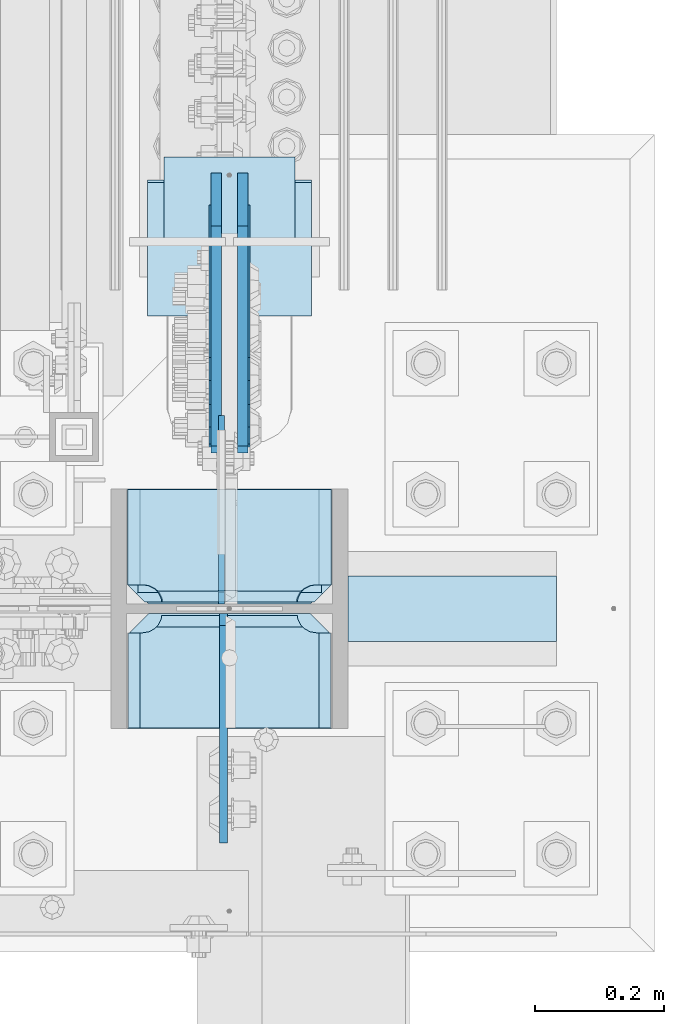
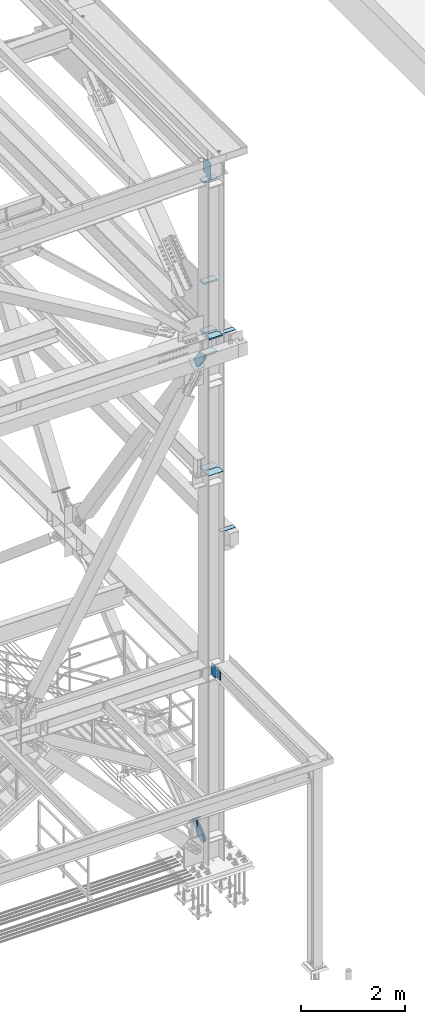
# One storey, part 3567 of 3843: 17 plates, 9 elements without a shape of their own.
"""IFC2X3 building model written with IfcOpenShell, lengths in millimetres."""

import ifcopenshell
import ifcopenshell.guid

model = None  # the IFC model being written
_history = None  # IfcOwnerHistory: only IFC2X3 demands one
_inside = {}  # id of a spatial element -> (the spatial element, [elements in it])
_under = {}  # id of a project, library or spatial element -> (it, [spatial elements below it])
_declared = {}  # id of a project -> (the project, [libraries it declares])
_typed = {}  # id of a type object -> (the type object, [elements of that type])
_made_of = {}  # id of a material, layer set ... -> (it, [elements and type objects made of it])


def new_model(schema):
    """Start an empty IFC model of exactly this schema.

    Asked for "IFC4X3", IfcOpenShell would pick the latest addendum, in which some entities
    have other attributes; the version numbers below select the first issue.
    IFC2X3 requires an IfcOwnerHistory on every rooted entity: one is made here for all.
    """
    global model, _history
    if schema == "IFC4X3":
        model = ifcopenshell.file(schema_version=(4, 3, 0, 0))
    else:
        model = ifcopenshell.file(schema=schema)
    _inside.clear()
    _under.clear()
    _declared.clear()
    _typed.clear()
    _made_of.clear()
    _history = None
    if model.schema == "IFC2X3":
        org = make("IfcOrganization", Name="unknown")
        user = make(
            "IfcPersonAndOrganization",
            ThePerson=make("IfcPerson", FamilyName="unknown"),
            TheOrganization=org,
        )
        app = make(
            "IfcApplication",
            ApplicationDeveloper=org,
            Version="unknown",
            ApplicationFullName="unknown",
            ApplicationIdentifier="unknown",
        )
        _history = make(
            "IfcOwnerHistory",
            OwningUser=user,
            OwningApplication=app,
            ChangeAction="ADDED",
            CreationDate=0,
        )
    return model


def make(cls, **values):
    """One entity of the class cls with the attributes given. An attribute that is None is left unset."""
    return model.create_entity(
        cls, **{name: value for name, value in values.items() if value is not None}
    )


def rooted(cls, **values):
    """An entity with a GlobalId (a new one), such as an element, a storey or a relation."""
    return make(cls, GlobalId=ifcopenshell.guid.new(), OwnerHistory=_history, **values)


def si_unit(unit_type, name, prefix=None):
    """IfcSIUnit, for example si_unit("LENGTHUNIT", "METRE", prefix="MILLI")."""
    return make("IfcSIUnit", UnitType=unit_type, Prefix=prefix, Name=name)


def assignment(units):
    """IfcUnitAssignment: the units of a project."""
    return None if units is None else make("IfcUnitAssignment", Units=units)


def point(xyz):
    """IfcCartesianPoint."""
    return None if xyz is None else make("IfcCartesianPoint", Coordinates=xyz)


def direction(xyz):
    """IfcDirection."""
    return None if xyz is None else make("IfcDirection", DirectionRatios=xyz)


def frame(location, z_axis=None, x_axis=None):
    """IfcAxis2Placement3D, a coordinate frame: its origin and axes. An axis left out is left unset."""
    return make(
        "IfcAxis2Placement3D",
        Location=point(location),
        Axis=direction(z_axis),
        RefDirection=direction(x_axis),
    )


def origin_with_axes():
    """The frame at (0, 0, 0) with the z axis (0, 0, 1) and the x axis (1, 0, 0) written out."""
    return frame((0.0, 0.0, 0.0), z_axis=(0.0, 0.0, 1.0), x_axis=(1.0, 0.0, 0.0))


def place(relative_to, where):
    """IfcLocalPlacement: puts the frame where relative to a parent placement (None: the world)."""
    return make(
        "IfcLocalPlacement", PlacementRelTo=relative_to, RelativePlacement=where
    )


def context(
    kind, dimensions, precision=None, world=None, true_north=None, identifier=None
):
    """IfcGeometricRepresentationContext, for example the 3D "Model" context."""
    return make(
        "IfcGeometricRepresentationContext",
        ContextIdentifier=identifier,
        ContextType=kind,
        CoordinateSpaceDimension=dimensions,
        Precision=precision,
        WorldCoordinateSystem=world,
        TrueNorth=true_north,
    )


def subcontext(parent, identifier, kind, view, scale=None):
    """IfcGeometricRepresentationSubContext, for example "Body" below "Model"."""
    return make(
        "IfcGeometricRepresentationSubContext",
        ContextIdentifier=identifier,
        ContextType=kind,
        ParentContext=parent,
        TargetScale=scale,
        TargetView=view,
    )


def project(units=None, contexts=None):
    """IfcProject with its units and contexts."""
    return rooted(
        "IfcProject",
        Name="project",
        RepresentationContexts=contexts,
        UnitsInContext=assignment(units),
    )


def spatial(cls, under=None, at=None, **own):
    """A site, building, storey or space (cls), placed at a placement, below another one or the project."""
    s = rooted(cls, ObjectPlacement=at, **own)
    if under is not None:
        _under.setdefault(under.id(), (under, []))[1].append(s)
    return s


def faces_of(points, faces, orient=None, outer=None):
    """IfcFace entities. A face is a list of loops; a loop is a list of indices into points, from 0.

    orient and outer hold one flag for each loop. By default every Orientation is true, the
    first loop of a face is its IfcFaceOuterBound and the others are IfcFaceBound.
    """
    made = []
    for i, loops in enumerate(faces):
        bounds = []
        for j, loop in enumerate(loops):
            is_outer = j == 0 if outer is None else outer[i][j]
            bounds.append(
                make(
                    "IfcFaceOuterBound" if is_outer else "IfcFaceBound",
                    Bound=make("IfcPolyLoop", Polygon=[points[k] for k in loop]),
                    Orientation=True if orient is None else orient[i][j],
                )
            )
        made.append(make("IfcFace", Bounds=bounds))
    return made


def faceted_brep(points, faces, orient=None, outer=None, voids=None):
    """IfcFacetedBrep: a solid bounded by flat faces; with voids (closed shells), ...WithVoids."""
    shared = [point(p) for p in points]
    hull = make("IfcClosedShell", CfsFaces=faces_of(shared, faces, orient, outer))
    if voids is None:
        return make("IfcFacetedBrep", Outer=hull)
    return make(
        "IfcFacetedBrepWithVoids",
        Outer=hull,
        Voids=[
            make(cls, CfsFaces=faces_of(shared, fs, o, b)) for cls, fs, o, b in voids
        ],
    )


def shape(context_of_items, identifier, shape_type, items):
    """IfcShapeRepresentation: the items that make up one representation, for example the "Body"."""
    return make(
        "IfcShapeRepresentation",
        ContextOfItems=context_of_items,
        RepresentationIdentifier=identifier,
        RepresentationType=shape_type,
        Items=items,
    )


def material(Name=None, Category=None):
    """IfcMaterial."""
    return make("IfcMaterial", Name=Name, Category=Category)


def made_of(thing, what):
    """Note that an element or type object is made of a material, layer set ...; save() writes the relation."""
    if what is not None:
        _made_of.setdefault(what.id(), (what, []))[1].append(thing)
    return thing


def type_object(cls, material=None, **own):
    """A type object (cls), such as IfcWallType, which elements share."""
    return made_of(rooted(cls, **own), material)


def element(
    cls,
    number,
    at=None,
    inside=None,
    cuts=None,
    type_object=None,
    material=None,
    context=None,
    identifier="Body",
    shape_type=None,
    held_by="IfcProductDefinitionShape",
    body=None,
    shapes=None,
    **own,
):
    """One element of the class cls, such as IfcWall. Its Tag is "e" and its number.

    at: its placement. inside: the storey or other place that contains it. cuts: it is an
    opening in that element (IfcRelVoidsElement). A single representation is given by context,
    identifier, shape_type and body (its items); several are given by shapes. held_by: the class
    of the entity that holds the representations. save() writes the other relations.
    """
    e = rooted(cls, Tag="e%d" % number, ObjectPlacement=at, **own)
    if body is not None:
        shapes = [shape(context, identifier, shape_type, body)]
    if shapes is not None:
        e.Representation = make(held_by, Representations=shapes)
    if inside is not None:
        _inside.setdefault(inside.id(), (inside, []))[1].append(e)
    if cuts is not None:
        rooted(
            "IfcRelVoidsElement", RelatingBuildingElement=cuts, RelatedOpeningElement=e
        )
    if type_object is not None:
        _typed.setdefault(type_object.id(), (type_object, []))[1].append(e)
    return made_of(e, material)


def aggregate(whole, parts):
    """IfcRelAggregates: a whole, such as a stair, and the parts it consists of."""
    return rooted("IfcRelAggregates", RelatingObject=whole, RelatedObjects=parts)


def save(model, path):
    """Write the relations noted so far, then the file.

    IfcRelAggregates (storeys below a building ...), IfcRelContainedInSpatialStructure (elements
    in a storey), IfcRelDefinesByType, IfcRelAssociatesMaterial and IfcRelDeclares: one each for
    every whole, place, type object, material and project.
    """
    for whole, parts in _under.values():
        aggregate(whole, parts)
    for where, things in _inside.values():
        rooted(
            "IfcRelContainedInSpatialStructure",
            RelatedElements=things,
            RelatingStructure=where,
        )
    for kind, things in _typed.values():
        rooted("IfcRelDefinesByType", RelatedObjects=things, RelatingType=kind)
    for what, things in _made_of.values():
        rooted("IfcRelAssociatesMaterial", RelatedObjects=things, RelatingMaterial=what)
    for by, libraries in _declared.values():
        rooted("IfcRelDeclares", RelatingContext=by, RelatedDefinitions=libraries)
    model.write(path)


model = new_model("IFC2X3")

# Units and contexts
model_context = context("Model", 3, precision=1e-05, world=origin_with_axes())
body_context = subcontext(model_context, "Body", "Model", "MODEL_VIEW")
ifc_project = project(units=[si_unit("LENGTHUNIT", "METRE", prefix="MILLI"), si_unit("AREAUNIT", "SQUARE_METRE"), si_unit("VOLUMEUNIT", "CUBIC_METRE"), si_unit("MASSUNIT", "GRAM", prefix="KILO"), si_unit("TIMEUNIT", "SECOND"), si_unit("PLANEANGLEUNIT", "RADIAN"), si_unit("SOLIDANGLEUNIT", "STERADIAN"), si_unit("THERMODYNAMICTEMPERATUREUNIT", "DEGREE_CELSIUS"), si_unit("LUMINOUSINTENSITYUNIT", "LUMEN")], contexts=[model_context])

# Site, building, storey
site_placement = place(None, origin_with_axes())
site = spatial("IfcSite", under=ifc_project, at=site_placement, CompositionType="ELEMENT")
building_placement = place(site_placement, origin_with_axes())
building = spatial("IfcBuilding", under=site, at=building_placement, Name="Undefined", CompositionType="ELEMENT")
storey_placement = place(building_placement, origin_with_axes())
storey = spatial("IfcBuildingStorey", under=building, at=storey_placement, Name="Undefined", CompositionType="ELEMENT", Elevation=0.0)

# Assembly, plate
assembly_1_placement = place(storey_placement, origin_with_axes())
assembly_1 = element("IfcElementAssembly", 1, at=assembly_1_placement, inside=storey, Name="PLATE", AssemblyPlace="NOTDEFINED", PredefinedType="RIGID_FRAME")
ifc_material_1 = material(Name="STEEL/A572-50")
plate_type_1 = type_object("IfcPlateType", PredefinedType="NOTDEFINED")
plate_1_placement = place(assembly_1_placement, frame((85832.949622492, 14947.8999999997, 37749.1625), z_axis=(0.0, 1.0, 0.0), x_axis=(1.0, 0.0, 0.0)))
plate_1 = element("IfcPlate", 2, at=plate_1_placement, type_object=plate_type_1, material=ifc_material_1, Name="PLATE", context=body_context, shape_type="Brep", body=[
    faceted_brep([(0.0, -4.76249999999709, 0.0), (-0.000122492027003318, -4.76249999999709, 101.599998474121), (-0.000122492027003318, 4.76249999999709, 101.599998474121), (0.0, 4.76249999999709, 0.0), (323.849865722659, -4.76249999999709, 101.599998474121), (323.849865722659, 4.76249999999709, 101.599998474121), (323.849987792972, -4.76249999999709, -1.45519152283669e-11), (323.849987792972, 4.76249999999709, -1.45519152283669e-11)], [[[0, 1, 2, 3]], [[1, 4, 5, 2]], [[4, 6, 7, 5]], [[6, 0, 3, 7]], [[5, 7, 3, 2]], [[6, 4, 1, 0]]]),
])
aggregate(assembly_1, [plate_1])

assembly_2_placement = place(storey_placement, origin_with_axes())
assembly_2 = element("IfcElementAssembly", 3, at=assembly_2_placement, inside=storey, Name="PLATE", AssemblyPlace="NOTDEFINED", PredefinedType="RIGID_FRAME")
plate_2_placement = place(assembly_2_placement, frame((85832.949622492, 14947.8999999998, 42371.9625), z_axis=(0.0, 1.0, 0.0), x_axis=(1.0, 0.0, 0.0)))
plate_2 = element("IfcPlate", 4, at=plate_2_placement, type_object=plate_type_1, material=ifc_material_1, Name="PLATE", context=body_context, shape_type="Brep", body=[
    faceted_brep([(0.0, -4.76249999999709, 0.0), (-0.000122492027003318, -4.76249999999709, 101.599998474121), (-0.000122492027003318, 4.76249999999709, 101.599998474121), (0.0, 4.76249999999709, 0.0), (323.849865722659, -4.76249999999709, 101.599998474121), (323.849865722659, 4.76249999999709, 101.599998474121), (323.849987792972, -4.76249999999709, -1.45519152283669e-11), (323.849987792972, 4.76249999999709, -1.45519152283669e-11)], [[[0, 1, 2, 3]], [[1, 4, 5, 2]], [[4, 6, 7, 5]], [[6, 0, 3, 7]], [[5, 7, 3, 2]], [[6, 4, 1, 0]]]),
])
aggregate(assembly_2, [plate_2])

# Assembly, plates
assembly_3_placement = place(storey_placement, origin_with_axes())
assembly_3 = element("IfcElementAssembly", 5, at=assembly_3_placement, inside=storey, Name="COLUMN", AssemblyPlace="NOTDEFINED", PredefinedType="RIGID_FRAME")
plate_type_2 = type_object("IfcPlateType", PredefinedType="NOTDEFINED")
plate_3_placement = place(assembly_3_placement, frame((85809.1375, 14991.55625, 42452.925), z_axis=(-1.0, 0.0, 0.0), x_axis=(0.0, -1.0, 0.0)))
plate_3 = element("IfcPlate", 6, at=plate_3_placement, type_object=plate_type_2, material=ifc_material_1, Name="PLATE", context=body_context, shape_type="Brep", body=[
    faceted_brep([(17.7290728964945, 9.33296078367857, 270.873024980028), (21.5061209990872, 15.875, 274.650073082623), (21.5061209990872, 15.875, 46.0249269173801), (17.7290728964945, 9.33296078367857, 49.8019750199746), (9.32072521071495, -5.23072461579432, 54.0862421540805), (3.17524995231724, -15.875, 55.0595898134052), (3.17524995231724, -15.875, 265.615410186598), (9.32072521071677, -5.23072461578704, 266.588757845922), (177.799999999999, 15.875, 21.5053709990898), (177.799999999999, -15.875, 3.17449995232164), (30.1625003814697, -15.875, 3.17449995232164), (30.1625003814697, 15.875, 21.5053709990898), (30.1625003814697, 15.875, 299.168629000924), (30.1625003814697, -15.875, 317.499500047692), (177.799999999999, -15.875, 317.499500047692), (177.799999999999, 15.875, 299.168629000924), (9.32072521071677, -15.875, 266.588757845922), (17.7290728964945, -15.875, 270.873024980028), (24.4019754014498, -15.875, 277.545927484985), (24.4019754014498, 15.875, 277.545927484985), (28.6862425355521, -15.875, 285.954275170763), (28.6862425355521, 15.875, 285.954275170763), (30.1625003814697, -15.875, 295.275000381473), (30.1625003814697, 15.875, 295.275000381473), (30.1625003814697, -15.875, 25.3999996185303), (30.1625003814697, 15.875, 25.3999996185303), (28.6862425355521, -15.875, 34.7207248292398), (28.6862425355521, 15.875, 34.7207248292398), (24.4019754014498, -15.875, 43.1290725150175), (24.4019754014498, 15.875, 43.1290725150175), (17.7290728964945, -15.875, 49.8019750199746), (9.32072521071495, -15.875, 54.0862421540805)], [[[0, 1, 2, 3, 4, 5, 6, 7]], [[8, 9, 10, 11]], [[12, 13, 14, 15]], [[16, 7, 6]], [[16, 17, 0, 7]], [[17, 18, 19, 1, 0]], [[18, 20, 21, 19]], [[20, 22, 23, 21]], [[23, 22, 13, 12]], [[9, 8, 15, 14]], [[24, 25, 11, 10]], [[24, 26, 27, 25]], [[26, 28, 29, 27]], [[29, 28, 30, 3, 2]], [[30, 31, 4, 3]], [[31, 5, 4]], [[19, 21, 23, 12, 15, 8, 11, 25, 27, 29, 2, 1]], [[31, 30, 28, 26, 24, 10, 9, 14, 13, 22, 20, 18, 17, 16, 6, 5]]]),
])
plate_4_placement = place(assembly_3_placement, frame((85809.1375, 15183.64375, 41941.75), z_axis=(-1.0, 0.0, 0.0), x_axis=(0.0, -1.0, 0.0)))
plate_4 = element("IfcPlate", 7, at=plate_4_placement, type_object=plate_type_2, material=ifc_material_1, Name="PLATE", context=body_context, shape_type="Brep", body=[
    faceted_brep([(160.070927103507, 9.33296078367857, 49.8019750199746), (156.293879000928, 15.875, 46.0249269174055), (156.293879000928, 15.875, 274.650073082594), (160.070927103507, 9.33296078367857, 270.873024980028), (168.479274789286, -5.23072461578704, 266.588757845922), (174.624750047689, -15.875, 265.615398462905), (174.624750047689, -15.875, 55.0595893300633), (168.479274789286, -5.23072461578704, 54.0862421540805), (147.63749961853, 15.875, 21.5053709990898), (147.63749961853, -15.875, 3.17449995232164), (0.0, -15.875, 3.17449995232164), (0.0, 15.875, 21.5053709990898), (0.0, 15.875, 299.168629000924), (0.0, -15.875, 317.499500047692), (147.63749961853, -15.875, 317.499500047692), (147.63749961853, 15.875, 299.168629000924), (147.637499618531, -15.875, 295.275000381473), (147.637499618531, 15.875, 295.275000381473), (149.113757464449, -15.875, 285.954275170763), (149.113757464449, 15.875, 285.954275170763), (153.398024598551, -15.875, 277.545927484985), (153.398024598551, 15.875, 277.545927484985), (160.070927103507, -15.875, 270.873024980028), (168.479274789286, -15.875, 266.588757845922), (168.479274789286, -15.875, 54.0862421540805), (160.070927103507, -15.875, 49.8019750199746), (153.398024598551, -15.875, 43.1290725150175), (153.398024598551, 15.875, 43.1290725150175), (149.113757464449, -15.875, 34.7207248292398), (149.113757464449, 15.875, 34.7207248292398), (147.637499618531, -15.875, 25.3999996185303), (147.637499618531, 15.875, 25.3999996185303)], [[[0, 1, 2, 3, 4, 5, 6, 7]], [[8, 9, 10, 11]], [[12, 13, 14, 15]], [[13, 12, 11, 10]], [[16, 17, 15, 14]], [[16, 18, 19, 17]], [[18, 20, 21, 19]], [[21, 20, 22, 3, 2]], [[22, 23, 4, 3]], [[23, 5, 4]], [[24, 7, 6]], [[24, 25, 0, 7]], [[25, 26, 27, 1, 0]], [[26, 28, 29, 27]], [[28, 30, 31, 29]], [[31, 30, 9, 8]], [[27, 29, 31, 8, 11, 12, 15, 17, 19, 21, 2, 1]], [[9, 30, 28, 26, 25, 24, 6, 5, 23, 22, 20, 18, 16, 14, 13, 10]]]),
])
plate_5_placement = place(assembly_3_placement, frame((85809.1375, 15183.64375, 42452.925), z_axis=(-1.0, 0.0, 0.0), x_axis=(0.0, -1.0, 0.0)))
plate_5 = element("IfcPlate", 8, at=plate_5_placement, type_object=plate_type_2, material=ifc_material_1, Name="PLATE", context=body_context, shape_type="Brep", body=[
    faceted_brep([(160.070927103507, 9.33296078367857, 49.8019750199746), (156.293879000928, 15.875, 46.0249269174055), (156.293879000928, 15.875, 274.650073082594), (160.070927103507, 9.33296078367857, 270.873024980028), (168.479274789286, -5.23072461578704, 266.588757845922), (174.624750047689, -15.875, 265.615398462905), (174.624750047689, -15.875, 55.0595893300633), (168.479274789286, -5.23072461578704, 54.0862421540805), (147.63749961853, 15.875, 21.5053709990898), (147.63749961853, -15.875, 3.17449995232164), (0.0, -15.875, 3.17449995232164), (0.0, 15.875, 21.5053709990898), (0.0, 15.875, 299.168629000924), (0.0, -15.875, 317.499500047692), (147.63749961853, -15.875, 317.499500047692), (147.63749961853, 15.875, 299.168629000924), (147.637499618531, -15.875, 295.275000381473), (147.637499618531, 15.875, 295.275000381473), (149.113757464449, -15.875, 285.954275170763), (149.113757464449, 15.875, 285.954275170763), (153.398024598551, -15.875, 277.545927484985), (153.398024598551, 15.875, 277.545927484985), (160.070927103507, -15.875, 270.873024980028), (168.479274789286, -15.875, 266.588757845922), (168.479274789286, -15.875, 54.0862421540805), (160.070927103507, -15.875, 49.8019750199746), (153.398024598551, -15.875, 43.1290725150175), (153.398024598551, 15.875, 43.1290725150175), (149.113757464449, -15.875, 34.7207248292398), (149.113757464449, 15.875, 34.7207248292398), (147.637499618531, -15.875, 25.3999996185303), (147.637499618531, 15.875, 25.3999996185303)], [[[0, 1, 2, 3, 4, 5, 6, 7]], [[8, 9, 10, 11]], [[12, 13, 14, 15]], [[13, 12, 11, 10]], [[16, 17, 15, 14]], [[16, 18, 19, 17]], [[18, 20, 21, 19]], [[21, 20, 22, 3, 2]], [[22, 23, 4, 3]], [[23, 5, 4]], [[24, 7, 6]], [[24, 25, 0, 7]], [[25, 26, 27, 1, 0]], [[26, 28, 29, 27]], [[28, 30, 31, 29]], [[31, 30, 9, 8]], [[27, 29, 31, 8, 11, 12, 15, 17, 19, 21, 2, 1]], [[9, 30, 28, 26, 25, 24, 6, 5, 23, 22, 20, 18, 16, 14, 13, 10]]]),
])
plate_type_3 = type_object("IfcPlateType", PredefinedType="NOTDEFINED")
plate_6_placement = place(assembly_3_placement, frame((85807.55, 15183.64375, 45988.2875), z_axis=(-1.0, 0.0, 0.0), x_axis=(0.0, -1.0, 0.0)))
plate_6 = element("IfcPlate", 9, at=plate_6_placement, type_object=plate_type_3, material=ifc_material_1, Name="PLATE", context=body_context, shape_type="Brep", body=[
    faceted_brep([(160.070930155263, 10.9204547349436, 49.8019750199746), (158.126965665109, 14.2874999999985, 47.8580105298315), (158.126965665109, 14.2874999999985, 269.641989470168), (160.070930155263, 10.9204547349436, 267.698024980025), (168.479277841043, -3.64323066452198, 263.413757845919), (174.624750047689, -14.2874999999985, 262.440410669937), (174.624750047689, -14.2874999999985, 55.0595893300633), (168.479277841043, -3.64323066452198, 54.0862421540805), (0.0, -14.2874999999985, 0.0), (0.0, -14.2874999999985, 317.5), (0.0, 14.2874999999985, 317.5), (0.0, 14.2874999999985, 0.0), (147.637502670288, -14.2874999999985, 317.5), (147.637502670288, 14.2874999999985, 317.5), (147.637502670288, -14.2874999999985, 292.10000038147), (147.637502670288, 14.2874999999985, 292.10000038147), (149.113760516204, -14.2874999999985, 282.77927517076), (149.113760516204, 14.2874999999985, 282.77927517076), (153.398027650306, -14.2874999999985, 274.370927484983), (153.398027650306, 14.2874999999985, 274.370927484983), (160.070930155263, -14.2874999999985, 267.698024980025), (168.479277841041, -14.2874999999985, 263.413757845919), (168.479274789286, -14.2874999999985, 54.0862421540805), (160.070927103507, -14.2874999999985, 49.8019750199746), (153.398024598551, -14.2874999999985, 43.1290725150175), (153.398024598551, 14.2874999999985, 43.1290725150175), (149.113757464449, -14.2874999999985, 34.7207248292398), (149.113757464449, 14.2874999999985, 34.7207248292398), (147.637499618531, -14.2874999999985, 25.3999996185303), (147.637499618531, 14.2874999999985, 25.3999996185303), (147.637502670288, -14.2874999999985, 0.0), (147.637502670288, 14.2874999999985, 0.0)], [[[0, 1, 2, 3, 4, 5, 6, 7]], [[8, 9, 10, 11]], [[9, 12, 13, 10]], [[12, 14, 15, 13]], [[14, 16, 17, 15]], [[16, 18, 19, 17]], [[19, 18, 20, 3, 2]], [[20, 21, 4, 3]], [[21, 5, 4]], [[22, 7, 6]], [[22, 23, 0, 7]], [[23, 24, 25, 1, 0]], [[24, 26, 27, 25]], [[26, 28, 29, 27]], [[28, 30, 31, 29]], [[30, 8, 11, 31]], [[25, 27, 29, 31, 11, 10, 13, 15, 17, 19, 2, 1]], [[30, 28, 26, 24, 23, 22, 6, 5, 21, 20, 18, 16, 14, 12, 9, 8]]]),
])

# Assembly, plate
assembly_4_placement = place(storey_placement, origin_with_axes())
assembly_4 = element("IfcElementAssembly", 10, at=assembly_4_placement, inside=storey, Name="Plate", AssemblyPlace="NOTDEFINED", PredefinedType="RIGID_FRAME")
ifc_material_2 = material(Name="STEEL/A36")
plate_type_4 = type_object("IfcPlateType", PredefinedType="NOTDEFINED")
plate_7_placement = place(assembly_4_placement, frame((85750.4, 15697.687097068, 30606.3543272799), z_axis=(0.0, -0.644671805294096, 0.764459458348742), x_axis=(-1.0, 0.0, 0.0)))
plate_7 = element("IfcPlate", 11, at=plate_7_placement, type_object=plate_type_4, material=ifc_material_2, Name="Plate", context=body_context, shape_type="Brep", body=[
    faceted_brep([(0.0, -3.17499999999927, 0.0), (0.0, -3.17500000043947, 203.200000001736), (0.0, 3.1749999995518, 203.200000001743), (0.0, 3.17499999999927, 0.0), (203.200000000012, -3.17500000043947, 203.200000001736), (203.200000000012, 3.1749999995518, 203.200000001743), (203.199996948242, -3.17499999999927, 0.0), (203.199996948242, 3.17499999999927, 0.0)], [[[0, 1, 2, 3]], [[1, 4, 5, 2]], [[4, 6, 7, 5]], [[6, 0, 3, 7]], [[5, 7, 3, 2]], [[6, 4, 1, 0]]]),
])
aggregate(assembly_4, [plate_7])

assembly_5_placement = place(storey_placement, origin_with_axes())
assembly_5 = element("IfcElementAssembly", 12, at=assembly_5_placement, inside=storey, AssemblyPlace="NOTDEFINED", PredefinedType="RIGID_FRAME")
plate_type_5 = type_object("IfcPlateType", PredefinedType="NOTDEFINED")
plate_8_placement = place(assembly_5_placement, frame((85626.575, 15585.3923492607, 41498.5773200445), z_axis=(0.0, -0.818772763967613, -0.574117723977265), x_axis=(0.0, 0.574117723977282, -0.818772763967601)))
plate_8 = element("IfcPlate", 13, at=plate_8_placement, type_object=plate_type_5, material=ifc_material_2, context=body_context, shape_type="Brep", body=[
    faceted_brep([(0.0, -9.52500000000146, 0.0), (-101.599999999169, -9.52499999999418, -17.6403935107228), (-101.599999999169, 9.52499999999418, -17.6403935107228), (0.0, 9.52500000000146, 0.0), (-320.279297659972, -9.52499999999418, -17.640393512258), (-320.279297659972, 9.52499999999418, -17.640393512258), (-357.3374051259, -9.52499999999418, -10.2690776257878), (-357.3374051259, 9.52499999999418, -10.2690776257878), (-388.753751662653, -9.52499999999418, 10.7226540115298), (-388.753751662653, 9.52499999999418, 10.7226540115298), (-409.745483299826, -9.52499999999418, 42.1390005483918), (-409.745483299826, 9.52499999999418, 42.1390005483918), (-417.116799186137, -9.52499999999418, 79.1971049608474), (-417.116799186137, 9.52499999999418, 79.1971049608474), (-409.745483299252, -9.52499999999418, 116.255212426157), (-409.745483299252, 9.52499999999418, 116.255212426157), (-388.75375166202, -9.52499999999418, 147.671558962465), (-388.75375166202, 9.52499999999418, 147.671558962465), (-357.33740512564, -9.52499999999418, 168.663290599579), (-357.33740512564, 9.52499999999418, 168.663290599579), (-320.279299186061, -9.52499999999418, 176.034606486319), (-320.279299186061, 9.52499999999418, 176.034606486319), (-101.599999997048, -9.52499999999418, 176.034606487883), (-101.599999997048, 9.52499999999418, 176.034606487883), (1.71894498635083e-09, -9.52499999999418, 158.39421297863), (1.71894498635083e-09, 9.52499999999418, 158.39421297863), (69.8500000010408, -9.52499999999418, 158.394212979103), (69.8500000010408, 9.52499999999418, 158.394212979103), (69.8499999979995, -9.52499999999418, -4.00177668780088e-10), (69.8499999979995, 9.52499999999418, -4.00177668780088e-10)], [[[0, 1, 2, 3]], [[1, 4, 5, 2]], [[4, 6, 7, 5]], [[6, 8, 9, 7]], [[8, 10, 11, 9]], [[10, 12, 13, 11]], [[12, 14, 15, 13]], [[14, 16, 17, 15]], [[16, 18, 19, 17]], [[18, 20, 21, 19]], [[20, 22, 23, 21]], [[22, 24, 25, 23]], [[24, 26, 27, 25]], [[26, 28, 29, 27]], [[28, 0, 3, 29]], [[5, 7, 9, 11, 13, 15, 17, 19, 21, 23, 25, 27, 29, 3, 2]], [[28, 26, 24, 22, 20, 18, 16, 14, 12, 10, 8, 6, 4, 1, 0]]]),
])
aggregate(assembly_5, [plate_8])

assembly_6_placement = place(storey_placement, origin_with_axes())
assembly_6 = element("IfcElementAssembly", 14, at=assembly_6_placement, inside=storey, AssemblyPlace="NOTDEFINED", PredefinedType="RIGID_FRAME")
plate_9_placement = place(assembly_6_placement, frame((85671.025, 15585.3923492607, 41498.5773200445), z_axis=(0.0, -0.818772763967613, -0.574117723977265), x_axis=(0.0, 0.574117723977282, -0.818772763967601)))
plate_9 = element("IfcPlate", 15, at=plate_9_placement, type_object=plate_type_5, material=ifc_material_2, context=body_context, shape_type="Brep", body=[
    faceted_brep([(0.0, -9.52500000000146, 0.0), (-101.599999999169, -9.52499999999418, -17.6403935107228), (-101.599999999169, 9.52499999999418, -17.6403935107228), (0.0, 9.52500000000146, 0.0), (-320.279297659972, -9.52499999999418, -17.640393512258), (-320.279297659972, 9.52499999999418, -17.640393512258), (-357.3374051259, -9.52499999999418, -10.2690776257878), (-357.3374051259, 9.52499999999418, -10.2690776257878), (-388.753751662653, -9.52499999999418, 10.7226540115298), (-388.753751662653, 9.52499999999418, 10.7226540115298), (-409.745483299826, -9.52499999999418, 42.1390005483918), (-409.745483299826, 9.52499999999418, 42.1390005483918), (-417.116799186137, -9.52499999999418, 79.1971049608474), (-417.116799186137, 9.52499999999418, 79.1971049608474), (-409.745483299252, -9.52499999999418, 116.255212426157), (-409.745483299252, 9.52499999999418, 116.255212426157), (-388.75375166202, -9.52499999999418, 147.671558962465), (-388.75375166202, 9.52499999999418, 147.671558962465), (-357.33740512564, -9.52499999999418, 168.663290599579), (-357.33740512564, 9.52499999999418, 168.663290599579), (-320.279299186061, -9.52499999999418, 176.034606486319), (-320.279299186061, 9.52499999999418, 176.034606486319), (-101.599999997048, -9.52499999999418, 176.034606487883), (-101.599999997048, 9.52499999999418, 176.034606487883), (1.71894498635083e-09, -9.52499999999418, 158.39421297863), (1.71894498635083e-09, 9.52499999999418, 158.39421297863), (69.8500000010408, -9.52499999999418, 158.394212979103), (69.8500000010408, 9.52499999999418, 158.394212979103), (69.8499999979995, -9.52499999999418, -4.00177668780088e-10), (69.8499999979995, 9.52499999999418, -4.00177668780088e-10)], [[[0, 1, 2, 3]], [[1, 4, 5, 2]], [[4, 6, 7, 5]], [[6, 8, 9, 7]], [[8, 10, 11, 9]], [[10, 12, 13, 11]], [[12, 14, 15, 13]], [[14, 16, 17, 15]], [[16, 18, 19, 17]], [[18, 20, 21, 19]], [[20, 22, 23, 21]], [[22, 24, 25, 23]], [[24, 26, 27, 25]], [[26, 28, 29, 27]], [[28, 0, 3, 29]], [[5, 7, 9, 11, 13, 15, 17, 19, 21, 23, 25, 27, 29, 3, 2]], [[28, 26, 24, 22, 20, 18, 16, 14, 12, 10, 8, 6, 4, 1, 0]]]),
])
aggregate(assembly_6, [plate_9])

assembly_7_placement = place(storey_placement, origin_with_axes())
assembly_7 = element("IfcElementAssembly", 16, at=assembly_7_placement, inside=storey, Name="Plate", AssemblyPlace="NOTDEFINED", PredefinedType="RIGID_FRAME")
plate_type_6 = type_object("IfcPlateType", PredefinedType="NOTDEFINED")
plate_10_placement = place(assembly_7_placement, frame((85521.8, 15454.8430732882, 41325.6042322667), z_axis=(0.0, 0.818772763967602, 0.574117723977281), x_axis=(1.0, 0.0, 0.0)))
plate_10 = element("IfcPlate", 17, at=plate_10_placement, type_object=plate_type_6, material=ifc_material_2, Name="Plate", context=body_context, shape_type="Brep", body=[
    faceted_brep([(0.0, -3.17499999999927, 0.0), (0.0, -3.17499999965185, 254.000000005151), (0.0, 3.17500000035216, 254.000000005166), (0.0, 3.17499999999927, 0.0), (254.0, -3.17499999965185, 254.000000005151), (254.0, 3.17500000035216, 254.000000005166), (254.0, -3.17500000000291, 0.0), (254.0, 3.17499999999927, 1.45519152283669e-11)], [[[0, 1, 2, 3]], [[1, 4, 5, 2]], [[4, 6, 7, 5]], [[6, 0, 3, 7]], [[5, 7, 3, 2]], [[6, 4, 1, 0]]]),
])
aggregate(assembly_7, [plate_10])

assembly_8_placement = place(storey_placement, origin_with_axes())
assembly_8 = element("IfcElementAssembly", 18, at=assembly_8_placement, inside=storey, AssemblyPlace="NOTDEFINED", PredefinedType="RIGID_FRAME")
plate_type_7 = type_object("IfcPlateType", PredefinedType="NOTDEFINED")
plate_11_placement = place(assembly_8_placement, frame((85628.1625, 15622.3182892789, 30592.302833254), z_axis=(0.0, -0.644671805294096, 0.764459458348742), x_axis=(0.0, 0.764459458348741, 0.644671805294097)))
plate_11 = element("IfcPlate", 19, at=plate_11_placement, type_object=plate_type_7, material=ifc_material_2, context=body_context, shape_type="Brep", body=[
    faceted_brep([(0.0, -7.9375, 0.0), (-101.599999998451, -7.9375, -31.4963478657155), (-101.599999998451, 7.9375, -31.4963478657155), (0.0, 7.9375, 0.0), (-320.921138847057, -7.9375, -31.4963478655336), (-320.921138847057, 7.9375, -31.4963478655336), (-357.371735779619, -7.9375, -24.2458733372187), (-357.371735779619, 7.9375, -24.2458733372187), (-388.273059754701, -7.9375, -3.59826877355954), (-388.273059754701, 7.9375, -3.59826877355954), (-408.92066431832, -7.9375, 27.3030552016353), (-408.92066431832, 7.9375, 27.3030552016353), (-416.171138846671, -7.9375, 63.7536521347356), (-416.171138846671, 7.9375, 63.7536521347356), (-408.920664318482, -7.9375, 100.204249067661), (-408.920664318482, 7.9375, 100.204249067661), (-388.273059754884, -7.9375, 131.105573043053), (-388.273059754884, 7.9375, 131.105573043053), (-357.371735779699, -7.9375, 151.753177606828), (-357.371735779699, 7.9375, 151.753177606828), (-320.921138848337, -7.9375, 159.003652135143), (-320.921138848337, 7.9375, 159.003652135143), (-101.599999999054, -7.9375, 159.003652134947), (-101.599999999054, 7.9375, 159.003652134947), (-4.01087163481861e-10, -7.9375, 127.507304269042), (-4.01087163481861e-10, 7.9375, 127.507304269042), (69.8499999986043, -7.9375, 127.507304268976), (69.8499999986043, 7.9375, 127.507304268976), (69.850000000486, -7.9375, 2.91038304567337e-11), (69.850000000486, 7.9375, 2.91038304567337e-11)], [[[0, 1, 2, 3]], [[1, 4, 5, 2]], [[4, 6, 7, 5]], [[6, 8, 9, 7]], [[8, 10, 11, 9]], [[10, 12, 13, 11]], [[12, 14, 15, 13]], [[14, 16, 17, 15]], [[16, 18, 19, 17]], [[18, 20, 21, 19]], [[20, 22, 23, 21]], [[22, 24, 25, 23]], [[24, 26, 27, 25]], [[26, 28, 29, 27]], [[28, 0, 3, 29]], [[5, 7, 9, 11, 13, 15, 17, 19, 21, 23, 25, 27, 29, 3, 2]], [[28, 26, 24, 22, 20, 18, 16, 14, 12, 10, 8, 6, 4, 1, 0]]]),
])
aggregate(assembly_8, [plate_11])

assembly_9_placement = place(storey_placement, origin_with_axes())
assembly_9 = element("IfcElementAssembly", 20, at=assembly_9_placement, inside=storey, AssemblyPlace="NOTDEFINED", PredefinedType="RIGID_FRAME")
plate_12_placement = place(assembly_9_placement, frame((85669.4375, 15622.3182892789, 30592.302833254), z_axis=(0.0, -0.644671805294096, 0.764459458348742), x_axis=(0.0, 0.764459458348741, 0.644671805294097)))
plate_12 = element("IfcPlate", 21, at=plate_12_placement, type_object=plate_type_7, material=ifc_material_2, context=body_context, shape_type="Brep", body=[
    faceted_brep([(0.0, -7.9375, 0.0), (-101.599999998451, -7.9375, -31.4963478657155), (-101.599999998451, 7.9375, -31.4963478657155), (0.0, 7.9375, 0.0), (-320.921138847057, -7.9375, -31.4963478655336), (-320.921138847057, 7.9375, -31.4963478655336), (-357.371735779619, -7.9375, -24.2458733372187), (-357.371735779619, 7.9375, -24.2458733372187), (-388.273059754701, -7.9375, -3.59826877355954), (-388.273059754701, 7.9375, -3.59826877355954), (-408.92066431832, -7.9375, 27.3030552016353), (-408.92066431832, 7.9375, 27.3030552016353), (-416.171138846671, -7.9375, 63.7536521347356), (-416.171138846671, 7.9375, 63.7536521347356), (-408.920664318482, -7.9375, 100.204249067661), (-408.920664318482, 7.9375, 100.204249067661), (-388.273059754884, -7.9375, 131.105573043053), (-388.273059754884, 7.9375, 131.105573043053), (-357.371735779699, -7.9375, 151.753177606828), (-357.371735779699, 7.9375, 151.753177606828), (-320.921138848337, -7.9375, 159.003652135143), (-320.921138848337, 7.9375, 159.003652135143), (-101.599999999054, -7.9375, 159.003652134947), (-101.599999999054, 7.9375, 159.003652134947), (-4.01087163481861e-10, -7.9375, 127.507304269042), (-4.01087163481861e-10, 7.9375, 127.507304269042), (69.8499999986043, -7.9375, 127.507304268976), (69.8499999986043, 7.9375, 127.507304268976), (69.850000000486, -7.9375, 2.91038304567337e-11), (69.850000000486, 7.9375, 2.91038304567337e-11)], [[[0, 1, 2, 3]], [[1, 4, 5, 2]], [[4, 6, 7, 5]], [[6, 8, 9, 7]], [[8, 10, 11, 9]], [[10, 12, 13, 11]], [[12, 14, 15, 13]], [[14, 16, 17, 15]], [[16, 18, 19, 17]], [[18, 20, 21, 19]], [[20, 22, 23, 21]], [[22, 24, 25, 23]], [[24, 26, 27, 25]], [[26, 28, 29, 27]], [[28, 0, 3, 29]], [[5, 7, 9, 11, 13, 15, 17, 19, 21, 23, 25, 27, 29, 3, 2]], [[28, 26, 24, 22, 20, 18, 16, 14, 12, 10, 8, 6, 4, 1, 0]]]),
])
aggregate(assembly_9, [plate_12])

# Plate
plate_type_8 = type_object("IfcPlateType", PredefinedType="NOTDEFINED")
plate_13_placement = place(assembly_3_placement, frame((85809.1375, 15005.84375, 43621.7046658719), z_axis=(-1.0, 0.0, 0.0), x_axis=(0.0, 1.0, 0.0)))
plate_13 = element("IfcPlate", 22, at=plate_13_placement, type_object=plate_type_8, material=ifc_material_1, Name="PLATE", context=body_context, shape_type="Brep", body=[
    faceted_brep([(28.5745000476891, 12.6999999999971, 317.499500047692), (177.799950000001, 12.6999999999971, 317.499500047692), (177.799950000001, 12.6999999999971, 3.17449995232164), (28.5755000476784, 12.6999999999971, 3.17449995232164), (3.17524995231724, 12.6999999999971, 28.5747500476864), (3.17524995231724, 12.6999999999971, 292.100249952317), (15.8748595754369, -9.29642286615126, 304.799859575447), (177.799950000001, -12.6999999999971, 302.834803430524), (17.8399465694929, -12.6999999999971, 302.834803430524), (177.799950000001, -12.6999999999971, 17.83919656949), (17.8399465694929, -12.6999999999971, 17.83919656949), (15.8753595793569, -9.29728888475802, 15.8746404206468)], [[[0, 1, 2, 3, 4, 5]], [[0, 5, 6]], [[7, 1, 0, 6, 8]], [[9, 2, 1, 7]], [[3, 2, 9, 10, 11]], [[3, 11, 4]], [[10, 8, 6, 5, 4, 11]], [[9, 7, 8, 10]]]),
])

plate_type_9 = type_object("IfcPlateType", PredefinedType="NOTDEFINED")
plate_14_placement = place(assembly_3_placement, frame((85636.0995000839, 15005.84375, 46021.625), z_axis=(0.0, 0.707106781186548, 0.707106781186548), x_axis=(5.70000238222118e-08, 0.707106781186546, -0.707106781186546)))
plate_14 = element("IfcPlate", 23, at=plate_14_placement, type_object=plate_type_9, material=ifc_material_1, Name="PLATE", context=body_context, shape_type="Brep", body=[
    faceted_brep([(0.0, -4.76249999999709, 0.0), (-273.897811691269, -4.76249999999709, 273.897811691328), (-273.897811691269, 4.76249999999709, 273.897811691328), (0.0, 4.76249999999709, 0.0), (-273.897811691131, -4.76249999999709, 300.83858005454), (-273.897811691131, 4.76249999999709, 300.83858005454), (-161.644610177136, -4.76249999999709, 413.09178156851), (-161.644610177136, 4.76249999999709, 413.09178156851), (-132.458777648957, -4.76249999999709, 383.905949040323), (-132.458777648957, 4.76249999999709, 383.905949040323), (-128.338601180818, -4.76249999999709, 381.152935139853), (-128.338601180818, 4.76249999999709, 381.152935139853), (-123.478521662786, -4.76249999999709, 380.186205217266), (-123.478521662786, 4.76249999999709, 380.186205217266), (-118.618442144754, -4.76249999999709, 381.152935139853), (-118.618442144754, 4.76249999999709, 381.152935139853), (-114.498265676601, -4.76249999999709, 383.90594904032), (-114.498265676601, 4.76249999999709, 383.90594904032), (-42.0949505651442, -4.76249999999709, 456.309264151772), (-42.0949505651442, 4.76249999999709, 456.309264151772), (182.411452460481, -4.76249999999709, 231.802861126107), (182.411452460481, 4.76249999999709, 231.802861126107), (110.008137349017, -4.76249999999709, 159.399546014654), (110.008137349017, 4.76249999999709, 159.399546014654), (107.255123448544, -4.76249999999709, 155.279369546512), (107.255123448544, 4.76249999999709, 155.279369546512), (106.288393525967, -4.76249999999709, 150.41929002848), (106.288393525967, 4.76249999999709, 150.41929002848), (107.255123448551, -4.76249999999709, 145.559210510441), (107.255123448551, 4.76249999999709, 145.559210510441), (110.008137349017, -4.76249999999709, 141.439034042298), (110.008137349017, 4.76249999999709, 141.439034042298), (139.193969877184, -4.76249999999709, 112.253201514119), (139.193969877184, 4.76249999999709, 112.253201514119), (26.9407683631998, -4.76249999999709, 1.30967237055302e-10), (26.9407683631998, 4.76249999999709, 1.30967237055302e-10)], [[[0, 1, 2, 3]], [[1, 4, 5, 2]], [[4, 6, 7, 5]], [[6, 8, 9, 7]], [[8, 10, 11, 9]], [[10, 12, 13, 11]], [[12, 14, 15, 13]], [[14, 16, 17, 15]], [[16, 18, 19, 17]], [[18, 20, 21, 19]], [[20, 22, 23, 21]], [[22, 24, 25, 23]], [[24, 26, 27, 25]], [[26, 28, 29, 27]], [[28, 30, 31, 29]], [[30, 32, 33, 31]], [[32, 34, 35, 33]], [[34, 0, 3, 35]], [[5, 7, 9, 11, 13, 15, 17, 19, 21, 23, 25, 27, 29, 31, 33, 35, 3, 2]], [[34, 32, 30, 28, 26, 24, 22, 20, 18, 16, 14, 12, 10, 8, 6, 4, 1, 0]]]),
])

plate_type_10 = type_object("IfcPlateType", PredefinedType="NOTDEFINED")
plate_15_placement = place(assembly_3_placement, frame((85639.2749999046, 14991.55625, 34496.375), z_axis=(0.0, -0.707106781186682, 0.707106781186413), x_axis=(0.0, -0.707106781186548, -0.707106781186548)))
plate_15 = element("IfcPlate", 24, at=plate_15_placement, type_object=plate_type_10, material=ifc_material_1, Name="PLATE", context=body_context, shape_type="Brep", body=[
    faceted_brep([(0.0, -6.3499999046162, 0.0), (-184.095250481034, -6.35000000000582, 184.095250481028), (-184.095250481034, 6.35000000000582, 184.095250481028), (7.27595761418343e-12, 6.3499999046162, 0.0), (-184.095250480968, -6.35000000000582, 211.036018844183), (-184.095250480968, 6.35000000000582, 211.036018844183), (54.442802735015, -6.35000000000582, 449.574072060163), (54.442802735015, 6.35000000000582, 449.574072060163), (225.067669034506, -6.35000000000582, 278.949205760668), (225.067669034506, 6.35000000000582, 278.949205760668), (108.324339325693, -6.35000000000582, 162.205876051856), (108.324339325693, 6.35000000000582, 162.205876051856), (105.571325425219, -6.35000000000582, 158.085699583702), (105.571325425219, 6.35000000000582, 158.085699583702), (104.604595502627, -6.35000000000582, 153.225620065657), (104.604595502627, 6.35000000000582, 153.225620065657), (105.571325425204, -6.35000000000582, 148.365540547624), (105.571325425204, 6.35000000000582, 148.365540547624), (108.324339325678, -6.35000000000582, 144.245364079476), (108.324339325678, 6.35000000000582, 144.245364079476), (139.755235884106, -6.35000000000582, 112.814467521039), (139.755235884106, 6.35000000000582, 112.814467521039), (26.9407683632217, -6.34999999999854, 1.30967237055302e-10), (26.9407683632217, 6.34999999999854, 1.30967237055302e-10)], [[[0, 1, 2, 3]], [[1, 4, 5, 2]], [[4, 6, 7, 5]], [[6, 8, 9, 7]], [[8, 10, 11, 9]], [[10, 12, 13, 11]], [[12, 14, 15, 13]], [[14, 16, 17, 15]], [[16, 18, 19, 17]], [[18, 20, 21, 19]], [[20, 22, 23, 21]], [[22, 0, 3, 23]], [[5, 7, 9, 11, 13, 15, 17, 19, 21, 23, 3, 2]], [[22, 20, 18, 16, 14, 12, 10, 8, 6, 4, 1, 0]]]),
])

plate_type_11 = type_object("IfcPlateType", PredefinedType="NOTDEFINED")
plate_16_placement = place(assembly_3_placement, frame((85807.55, 14812.9625, 39265.225), z_axis=(-1.0, 0.0, 0.0), x_axis=(0.0, 1.0, 0.0)))
plate_16 = element("IfcPlate", 25, at=plate_16_placement, type_object=plate_type_11, material=ifc_material_1, Name="PLATE", context=body_context, shape_type="Brep", body=[
    faceted_brep([(0.0, -3.17499999999927, 0.0), (0.0, -3.17500000000291, 317.5), (0.0, 3.17500000000291, 317.5), (0.0, 3.17499999999927, 0.0), (145.256248474121, -3.17500000000291, 317.5), (145.256248474121, 3.17500000000291, 317.5), (178.59375, -3.17500000000291, 284.162498474121), (178.59375, 3.17500000000291, 284.162498474121), (178.59375, -3.17500000000291, 33.3375015258789), (178.59375, 3.17500000000291, 33.3375015258789), (145.256248474121, -3.17500000000291, 0.0), (145.256248474121, 3.17500000000291, 0.0)], [[[0, 1, 2, 3]], [[1, 4, 5, 2]], [[4, 6, 7, 5]], [[6, 8, 9, 7]], [[8, 10, 11, 9]], [[10, 0, 3, 11]], [[5, 7, 9, 11, 3, 2]], [[10, 8, 6, 4, 1, 0]]]),
])

plate_17_placement = place(assembly_3_placement, frame((85807.55, 15005.84375, 39265.225), z_axis=(-1.0, 0.0, 0.0), x_axis=(0.0, 1.0, 0.0)))
plate_17 = element("IfcPlate", 26, at=plate_17_placement, type_object=plate_type_11, material=ifc_material_1, Name="PLATE", context=body_context, shape_type="Brep", body=[
    faceted_brep([(0.0, -3.17500000000291, 33.3375015258789), (0.0, -3.17500000000291, 284.162498474121), (0.0, 3.17500000000291, 284.162498474121), (0.0, 3.17500000000291, 33.3375015258789), (33.3375015258789, -3.17500000000291, 317.5), (33.3375015258789, 3.17500000000291, 317.5), (178.59375, -3.17500000000291, 317.5), (178.59375, 3.17500000000291, 317.5), (178.59375, -3.17500000000291, 0.0), (178.59375, 3.17500000000291, 0.0), (33.3375015258789, -3.17500000000291, 0.0), (33.3375015258789, 3.17500000000291, 0.0)], [[[0, 1, 2, 3]], [[1, 4, 5, 2]], [[4, 6, 7, 5]], [[6, 8, 9, 7]], [[8, 10, 11, 9]], [[10, 0, 3, 11]], [[5, 7, 9, 11, 3, 2]], [[10, 8, 6, 4, 1, 0]]]),
])

aggregate(assembly_3, [plate_3, plate_4, plate_5, plate_13, plate_15, plate_6, plate_14, plate_16, plate_17])

save(model, "model.ifc")
